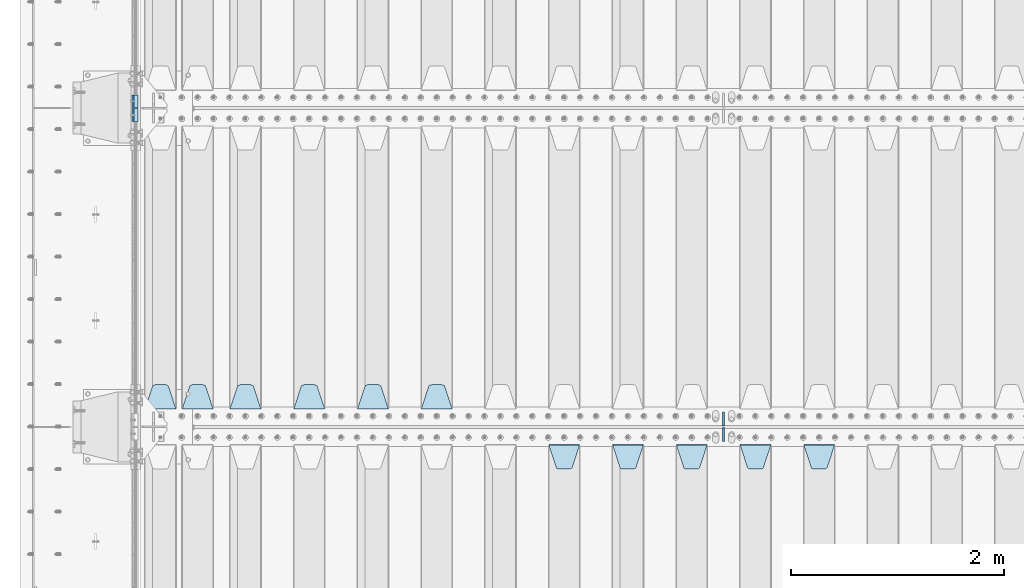
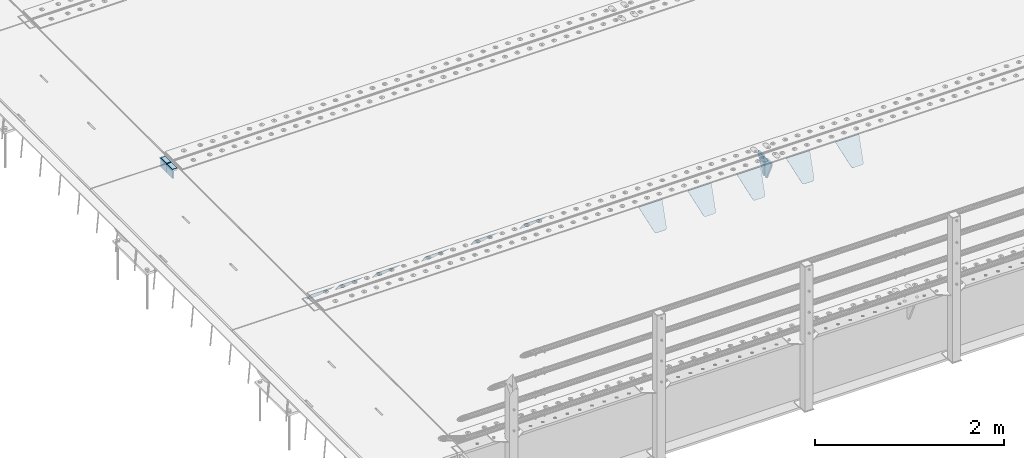
# One storey, part 205 of 257: 17 plates.
"""IFC2X3 building model written with IfcOpenShell, lengths in millimetres."""

from ifc_helpers import new_model, si_unit, frame, origin_with_axes, place, context, subcontext, project, spatial, faceted_brep, material, type_object, element, save


model = new_model("IFC2X3")

# Units and contexts
model_context = context("Model", 3, precision=1e-05, world=origin_with_axes())
body_context = subcontext(model_context, "Body", "Model", "MODEL_VIEW")
ifc_project = project(units=[si_unit("LENGTHUNIT", "METRE", prefix="MILLI"), si_unit("AREAUNIT", "SQUARE_METRE"), si_unit("VOLUMEUNIT", "CUBIC_METRE"), si_unit("MASSUNIT", "GRAM", prefix="KILO"), si_unit("TIMEUNIT", "SECOND"), si_unit("PLANEANGLEUNIT", "RADIAN"), si_unit("SOLIDANGLEUNIT", "STERADIAN"), si_unit("THERMODYNAMICTEMPERATUREUNIT", "DEGREE_CELSIUS"), si_unit("LUMINOUSINTENSITYUNIT", "LUMEN")], contexts=[model_context])

# Site, building, storey
site_placement = place(None, origin_with_axes())
site = spatial("IfcSite", under=ifc_project, at=site_placement, CompositionType="ELEMENT")
building_placement = place(site_placement, origin_with_axes())
building = spatial("IfcBuilding", under=site, at=building_placement, Name="Standard", CompositionType="ELEMENT")
storey_placement = place(building_placement, origin_with_axes())
storey = spatial("IfcBuildingStorey", under=building, at=storey_placement, Name="Undefined", CompositionType="ELEMENT", Elevation=0.0)

# Plates
ifc_material_1 = material()
plate_type_1 = type_object("IfcPlateType", PredefinedType="NOTDEFINED")
for number, where, z_axis, x_axis in (
    (1, (42440.00000006, 5935.00000043354, -16.0004050744733), (-1.0, 0.0, 0.0), (0.0, -4.95099999998473e-06, 0.999999999987744)),
    (2, (42439.99999994, 6065.00000045221, -16.0145962164944), (-1.0, 0.0, 0.0), (0.0, -4.95099999998473e-06, 0.999999999987744)),
):
    element("IfcPlate", number, at=place(storey_placement, frame(where, z_axis=z_axis, x_axis=x_axis)), inside=storey, type_object=plate_type_1, material=ifc_material_1, context=body_context, shape_type="Brep", body=[
        faceted_brep([(0.0, -60.0, 0.0), (-0.000933120085687023, -60.0, 60.0), (-0.000933120085687023, 60.0, 59.9999999999927), (0.0, 60.0, -7.27595761418343e-12), (24.9991450303709, -60.0, 60.0), (24.9991450303709, 60.0, 59.9999999999927), (26.544215218168, -60.0, 59.7552873850873), (26.544215218168, 60.0, 59.75528738508), (27.9380461396139, -60.0, 59.0451032459096), (27.9380461396139, 60.0, 59.0451032459096), (29.0442025908961, -60.0, 57.9389639895744), (29.0442025908961, 60.0, 57.9389639895744), (29.7544083969366, -60.0, 56.5451441080368), (29.7544083969366, 60.0, 56.5451441080295), (29.9991450297669, -60.0, 55.0000777244568), (29.9991450297669, 60.0, 55.0000777244495), (29.999922274335, -60.0, 5.00007772445679), (29.999922274335, 60.0, 5.00007772444951), (29.7552240705896, -60.0, 3.45497416452417), (29.7552240705896, 60.0, 3.45497416452417), (29.0450346578116, -60.0, 2.06111146690819), (29.0450346578116, 60.0, 2.06111146690819), (27.9388736885072, -60.0, 0.954933302316931), (27.9388736885072, 60.0, 0.954933302316931), (26.5450220308766, -60.0, 0.244722222181736), (26.5450220308766, 60.0, 0.244722222181736), (24.9999222749392, -60.0, 0.0), (24.9999222749392, 60.0, -7.27595761418343e-12)], [[[0, 1, 2, 3]], [[1, 4, 5, 2]], [[4, 6, 7, 5]], [[6, 8, 9, 7]], [[8, 10, 11, 9]], [[10, 12, 13, 11]], [[12, 14, 15, 13]], [[14, 16, 17, 15]], [[16, 18, 19, 17]], [[18, 20, 21, 19]], [[20, 22, 23, 21]], [[22, 24, 25, 23]], [[24, 26, 27, 25]], [[26, 0, 3, 27]], [[5, 7, 9, 11, 13, 15, 17, 19, 21, 23, 25, 27, 3, 2]], [[26, 24, 22, 20, 18, 16, 14, 12, 10, 8, 6, 4, 1, 0]]]),
    ])
ifc_material_2 = material(Name="STEEL/S355N")
plate_type_2 = type_object("IfcPlateType", PredefinedType="NOTDEFINED")
for number, where, z_axis, x_axis in (
    (3, (42390.0, 5995.00044598306, -106.000730104157), (0.0, -0.999999999987744, -4.95099999993769e-06), (0.0, -4.95099999998473e-06, 0.999999999987744)),
    (4, (42390.0, 6125.00044600192, -106.014921246643), (0.0, -0.999999999987744, -4.95099999993769e-06), (0.0, -4.95099999998473e-06, 0.999999999987744)),
):
    element("IfcPlate", number, at=place(storey_placement, frame(where, z_axis=z_axis, x_axis=x_axis)), inside=storey, type_object=plate_type_2, material=ifc_material_2, context=body_context, shape_type="Brep", body=[
        faceted_brep([(0.0, -10.0, 0.0), (5.7072624315424e-07, -10.0, 120.0), (5.7072624315424e-07, 10.0, 120.0), (0.0, 10.0, 0.0), (90.0, -10.0, 120.0), (90.0, 10.0, 120.0), (90.0, -10.0, 1.09139364212751e-11), (90.0, 10.0, 1.09139364212751e-11)], [[[0, 1, 2, 3]], [[1, 4, 5, 2]], [[4, 6, 7, 5]], [[6, 0, 3, 7]], [[5, 7, 3, 2]], [[6, 4, 1, 0]]]),
    ])
plate_type_3 = type_object("IfcPlateType", PredefinedType="NOTDEFINED")
plate_1_placement = place(storey_placement, frame((48705.0, 2831.76776695594, -1.767766952965), z_axis=(0.0, -0.707106781186548, -0.707106781186547), x_axis=(1.0, 0.0, 0.0)))
element("IfcPlate", 5, at=plate_1_placement, inside=storey, type_object=plate_type_3, material=ifc_material_2, context=body_context, shape_type="Brep", body=[
    faceted_brep([(0.0, -2.5, 0.0), (69.345504679477, -2.50000000000091, 300.17173142483), (69.345504679477, 2.5, 300.171731424831), (0.0, 2.5, 0.0), (70.927406119954, -2.50000000000091, 304.8974424154), (70.927406119954, 2.5, 304.8974424154), (73.3818627772271, -2.50000000000091, 309.234538108527), (73.3818627772271, 2.49999999999909, 309.234538108527), (76.6187032999587, -2.5, 313.023683126103), (76.6187032999587, 2.5, 313.023683126103), (80.5190132705029, -2.5, 316.125672595372), (80.5190132705029, 2.5, 316.125672595371), (84.9395038596849, -2.5, 318.426546230476), (84.9395038596849, 2.5, 318.426546230477), (89.7177759439219, -2.5, 319.841774983275), (89.7177759439219, 2.5, 319.841774983275), (94.6782862926484, -2.5, 320.319366455079), (94.6782862926484, 2.5, 320.319366455079), (195.321713707352, -2.5, 320.319366455079), (195.321713707352, 2.5, 320.319366455079), (200.282224056078, -2.5, 319.841774983275), (200.282224056078, 2.49999999999909, 319.841774983275), (205.060496140315, -2.5, 318.426546230476), (205.060496140315, 2.49999999999909, 318.426546230475), (209.480986729497, -2.5, 316.125672595371), (209.480986729497, 2.5, 316.125672595371), (213.381296700041, -2.50000000000091, 313.023683126102), (213.381296700041, 2.5, 313.023683126103), (216.618137222766, -2.50000000000091, 309.234538108527), (216.618137222766, 2.5, 309.234538108527), (219.072593880039, -2.5, 304.897442415399), (219.072593880039, 2.5, 304.897442415399), (220.654495320523, -2.50000000000091, 300.17173142483), (220.654495320523, 2.5, 300.171731424831), (290.0, -2.50000000000091, 0.0), (290.0, 2.5, 9.09494701772928e-13)], [[[0, 1, 2, 3]], [[1, 4, 5, 2]], [[4, 6, 7, 5]], [[6, 8, 9, 7]], [[8, 10, 11, 9]], [[10, 12, 13, 11]], [[12, 14, 15, 13]], [[14, 16, 17, 15]], [[16, 18, 19, 17]], [[18, 20, 21, 19]], [[20, 22, 23, 21]], [[22, 24, 25, 23]], [[24, 26, 27, 25]], [[26, 28, 29, 27]], [[28, 30, 31, 29]], [[30, 32, 33, 31]], [[32, 34, 35, 33]], [[34, 0, 3, 35]], [[5, 7, 9, 11, 13, 15, 17, 19, 21, 23, 25, 27, 29, 31, 33, 35, 3, 2]], [[34, 32, 30, 28, 26, 24, 22, 20, 18, 16, 14, 12, 10, 8, 6, 4, 1, 0]]]),
])
plate_2_placement = place(storey_placement, frame((48105.0, 2831.76776695594, -1.767766952965), z_axis=(0.0, -0.707106781186548, -0.707106781186547), x_axis=(1.0, 0.0, 0.0)))
element("IfcPlate", 6, at=plate_2_placement, inside=storey, type_object=plate_type_3, material=ifc_material_2, context=body_context, shape_type="Brep", body=[
    faceted_brep([(0.0, -2.5, 0.0), (69.345504679477, -2.50000000000091, 300.17173142483), (69.345504679477, 2.5, 300.171731424831), (0.0, 2.5, 0.0), (70.927406119954, -2.50000000000091, 304.8974424154), (70.927406119954, 2.5, 304.8974424154), (73.3818627772271, -2.50000000000091, 309.234538108527), (73.3818627772271, 2.49999999999909, 309.234538108527), (76.6187032999587, -2.5, 313.023683126103), (76.6187032999587, 2.5, 313.023683126103), (80.5190132705029, -2.5, 316.125672595372), (80.5190132705029, 2.5, 316.125672595371), (84.9395038596849, -2.5, 318.426546230476), (84.9395038596849, 2.5, 318.426546230477), (89.7177759439219, -2.5, 319.841774983275), (89.7177759439219, 2.5, 319.841774983275), (94.6782862926484, -2.5, 320.319366455079), (94.6782862926484, 2.5, 320.319366455079), (195.321713707352, -2.5, 320.319366455079), (195.321713707352, 2.5, 320.319366455079), (200.282224056078, -2.5, 319.841774983275), (200.282224056078, 2.49999999999909, 319.841774983275), (205.060496140315, -2.5, 318.426546230476), (205.060496140315, 2.49999999999909, 318.426546230475), (209.480986729497, -2.5, 316.125672595371), (209.480986729497, 2.5, 316.125672595371), (213.381296700041, -2.50000000000091, 313.023683126102), (213.381296700041, 2.5, 313.023683126103), (216.618137222766, -2.50000000000091, 309.234538108527), (216.618137222766, 2.5, 309.234538108527), (219.072593880039, -2.5, 304.897442415399), (219.072593880039, 2.5, 304.897442415399), (220.654495320523, -2.50000000000091, 300.17173142483), (220.654495320523, 2.5, 300.171731424831), (290.0, -2.50000000000091, 0.0), (290.0, 2.5, 9.09494701772928e-13)], [[[0, 1, 2, 3]], [[1, 4, 5, 2]], [[4, 6, 7, 5]], [[6, 8, 9, 7]], [[8, 10, 11, 9]], [[10, 12, 13, 11]], [[12, 14, 15, 13]], [[14, 16, 17, 15]], [[16, 18, 19, 17]], [[18, 20, 21, 19]], [[20, 22, 23, 21]], [[22, 24, 25, 23]], [[24, 26, 27, 25]], [[26, 28, 29, 27]], [[28, 30, 31, 29]], [[30, 32, 33, 31]], [[32, 34, 35, 33]], [[34, 0, 3, 35]], [[5, 7, 9, 11, 13, 15, 17, 19, 21, 23, 25, 27, 29, 31, 33, 35, 3, 2]], [[34, 32, 30, 28, 26, 24, 22, 20, 18, 16, 14, 12, 10, 8, 6, 4, 1, 0]]]),
])
plate_3_placement = place(storey_placement, frame((47505.0, 2831.76776695594, -1.767766952965), z_axis=(0.0, -0.707106781186548, -0.707106781186547), x_axis=(1.0, 0.0, 0.0)))
element("IfcPlate", 7, at=plate_3_placement, inside=storey, type_object=plate_type_3, material=ifc_material_2, context=body_context, shape_type="Brep", body=[
    faceted_brep([(0.0, -2.5, 0.0), (69.345504679477, -2.50000000000091, 300.17173142483), (69.345504679477, 2.5, 300.171731424831), (0.0, 2.5, 0.0), (70.927406119954, -2.50000000000091, 304.8974424154), (70.927406119954, 2.5, 304.8974424154), (73.3818627772271, -2.50000000000091, 309.234538108527), (73.3818627772271, 2.49999999999909, 309.234538108527), (76.6187032999587, -2.5, 313.023683126103), (76.6187032999587, 2.5, 313.023683126103), (80.5190132705029, -2.5, 316.125672595372), (80.5190132705029, 2.5, 316.125672595371), (84.9395038596849, -2.5, 318.426546230476), (84.9395038596849, 2.5, 318.426546230477), (89.7177759439219, -2.5, 319.841774983275), (89.7177759439219, 2.5, 319.841774983275), (94.6782862926484, -2.5, 320.319366455079), (94.6782862926484, 2.5, 320.319366455079), (195.321713707352, -2.5, 320.319366455079), (195.321713707352, 2.5, 320.319366455079), (200.282224056078, -2.5, 319.841774983275), (200.282224056078, 2.49999999999909, 319.841774983275), (205.060496140315, -2.5, 318.426546230476), (205.060496140315, 2.49999999999909, 318.426546230475), (209.480986729497, -2.5, 316.125672595371), (209.480986729497, 2.5, 316.125672595371), (213.381296700041, -2.50000000000091, 313.023683126102), (213.381296700041, 2.5, 313.023683126103), (216.618137222766, -2.50000000000091, 309.234538108527), (216.618137222766, 2.5, 309.234538108527), (219.072593880039, -2.5, 304.897442415399), (219.072593880039, 2.5, 304.897442415399), (220.654495320523, -2.50000000000091, 300.17173142483), (220.654495320523, 2.5, 300.171731424831), (290.0, -2.50000000000091, 0.0), (290.0, 2.5, 9.09494701772928e-13)], [[[0, 1, 2, 3]], [[1, 4, 5, 2]], [[4, 6, 7, 5]], [[6, 8, 9, 7]], [[8, 10, 11, 9]], [[10, 12, 13, 11]], [[12, 14, 15, 13]], [[14, 16, 17, 15]], [[16, 18, 19, 17]], [[18, 20, 21, 19]], [[20, 22, 23, 21]], [[22, 24, 25, 23]], [[24, 26, 27, 25]], [[26, 28, 29, 27]], [[28, 30, 31, 29]], [[30, 32, 33, 31]], [[32, 34, 35, 33]], [[34, 0, 3, 35]], [[5, 7, 9, 11, 13, 15, 17, 19, 21, 23, 25, 27, 29, 31, 33, 35, 3, 2]], [[34, 32, 30, 28, 26, 24, 22, 20, 18, 16, 14, 12, 10, 8, 6, 4, 1, 0]]]),
])
plate_4_placement = place(storey_placement, frame((46905.0, 2831.76776695594, -1.767766952965), z_axis=(0.0, -0.707106781186548, -0.707106781186547), x_axis=(1.0, 0.0, 0.0)))
element("IfcPlate", 8, at=plate_4_placement, inside=storey, type_object=plate_type_3, material=ifc_material_2, context=body_context, shape_type="Brep", body=[
    faceted_brep([(0.0, -2.5, 0.0), (69.345504679477, -2.50000000000091, 300.17173142483), (69.345504679477, 2.5, 300.171731424831), (0.0, 2.5, 0.0), (70.927406119954, -2.50000000000091, 304.8974424154), (70.927406119954, 2.5, 304.8974424154), (73.3818627772271, -2.50000000000091, 309.234538108527), (73.3818627772271, 2.49999999999909, 309.234538108527), (76.6187032999587, -2.5, 313.023683126103), (76.6187032999587, 2.5, 313.023683126103), (80.5190132705029, -2.5, 316.125672595372), (80.5190132705029, 2.5, 316.125672595371), (84.9395038596849, -2.5, 318.426546230476), (84.9395038596849, 2.5, 318.426546230477), (89.7177759439219, -2.5, 319.841774983275), (89.7177759439219, 2.5, 319.841774983275), (94.6782862926484, -2.5, 320.319366455079), (94.6782862926484, 2.5, 320.319366455079), (195.321713707352, -2.5, 320.319366455079), (195.321713707352, 2.5, 320.319366455079), (200.282224056078, -2.5, 319.841774983275), (200.282224056078, 2.49999999999909, 319.841774983275), (205.060496140315, -2.5, 318.426546230476), (205.060496140315, 2.49999999999909, 318.426546230475), (209.480986729497, -2.5, 316.125672595371), (209.480986729497, 2.5, 316.125672595371), (213.381296700041, -2.50000000000091, 313.023683126102), (213.381296700041, 2.5, 313.023683126103), (216.618137222766, -2.50000000000091, 309.234538108527), (216.618137222766, 2.5, 309.234538108527), (219.072593880039, -2.5, 304.897442415399), (219.072593880039, 2.5, 304.897442415399), (220.654495320523, -2.50000000000091, 300.17173142483), (220.654495320523, 2.5, 300.171731424831), (290.0, -2.50000000000091, 0.0), (290.0, 2.5, 9.09494701772928e-13)], [[[0, 1, 2, 3]], [[1, 4, 5, 2]], [[4, 6, 7, 5]], [[6, 8, 9, 7]], [[8, 10, 11, 9]], [[10, 12, 13, 11]], [[12, 14, 15, 13]], [[14, 16, 17, 15]], [[16, 18, 19, 17]], [[18, 20, 21, 19]], [[20, 22, 23, 21]], [[22, 24, 25, 23]], [[24, 26, 27, 25]], [[26, 28, 29, 27]], [[28, 30, 31, 29]], [[30, 32, 33, 31]], [[32, 34, 35, 33]], [[34, 0, 3, 35]], [[5, 7, 9, 11, 13, 15, 17, 19, 21, 23, 25, 27, 29, 31, 33, 35, 3, 2]], [[34, 32, 30, 28, 26, 24, 22, 20, 18, 16, 14, 12, 10, 8, 6, 4, 1, 0]]]),
])
plate_5_placement = place(storey_placement, frame((46305.0, 2831.76776695594, -1.767766952965), z_axis=(0.0, -0.707106781186548, -0.707106781186547), x_axis=(1.0, 0.0, 0.0)))
element("IfcPlate", 9, at=plate_5_placement, inside=storey, type_object=plate_type_3, material=ifc_material_2, context=body_context, shape_type="Brep", body=[
    faceted_brep([(0.0, -2.5, 0.0), (69.345504679477, -2.50000000000091, 300.17173142483), (69.345504679477, 2.5, 300.171731424831), (0.0, 2.5, 0.0), (70.927406119954, -2.50000000000091, 304.8974424154), (70.927406119954, 2.5, 304.8974424154), (73.3818627772271, -2.50000000000091, 309.234538108527), (73.3818627772271, 2.49999999999909, 309.234538108527), (76.6187032999587, -2.5, 313.023683126103), (76.6187032999587, 2.5, 313.023683126103), (80.5190132705029, -2.5, 316.125672595372), (80.5190132705029, 2.5, 316.125672595371), (84.9395038596849, -2.5, 318.426546230476), (84.9395038596849, 2.5, 318.426546230477), (89.7177759439219, -2.5, 319.841774983275), (89.7177759439219, 2.5, 319.841774983275), (94.6782862926484, -2.5, 320.319366455079), (94.6782862926484, 2.5, 320.319366455079), (195.321713707352, -2.5, 320.319366455079), (195.321713707352, 2.5, 320.319366455079), (200.282224056078, -2.5, 319.841774983275), (200.282224056078, 2.49999999999909, 319.841774983275), (205.060496140315, -2.5, 318.426546230476), (205.060496140315, 2.49999999999909, 318.426546230475), (209.480986729497, -2.5, 316.125672595371), (209.480986729497, 2.5, 316.125672595371), (213.381296700041, -2.50000000000091, 313.023683126102), (213.381296700041, 2.5, 313.023683126103), (216.618137222766, -2.50000000000091, 309.234538108527), (216.618137222766, 2.5, 309.234538108527), (219.072593880039, -2.5, 304.897442415399), (219.072593880039, 2.5, 304.897442415399), (220.654495320523, -2.50000000000091, 300.17173142483), (220.654495320523, 2.5, 300.171731424831), (290.0, -2.50000000000091, 0.0), (290.0, 2.5, 9.09494701772928e-13)], [[[0, 1, 2, 3]], [[1, 4, 5, 2]], [[4, 6, 7, 5]], [[6, 8, 9, 7]], [[8, 10, 11, 9]], [[10, 12, 13, 11]], [[12, 14, 15, 13]], [[14, 16, 17, 15]], [[16, 18, 19, 17]], [[18, 20, 21, 19]], [[20, 22, 23, 21]], [[22, 24, 25, 23]], [[24, 26, 27, 25]], [[26, 28, 29, 27]], [[28, 30, 31, 29]], [[30, 32, 33, 31]], [[32, 34, 35, 33]], [[34, 0, 3, 35]], [[5, 7, 9, 11, 13, 15, 17, 19, 21, 23, 25, 27, 29, 31, 33, 35, 3, 2]], [[34, 32, 30, 28, 26, 24, 22, 20, 18, 16, 14, 12, 10, 8, 6, 4, 1, 0]]]),
])
plate_6_placement = place(storey_placement, frame((45395.0, 3168.23223304703, -1.76776695296758), z_axis=(0.0, 0.707106781186547, -0.707106781186548), x_axis=(-1.0, 0.0, 0.0)))
element("IfcPlate", 10, at=plate_6_placement, inside=storey, type_object=plate_type_3, material=ifc_material_2, context=body_context, shape_type="Brep", body=[
    faceted_brep([(0.0, -2.5, 0.0), (69.345504679477, -2.50000000000091, 300.17173142483), (69.345504679477, 2.5, 300.171731424831), (0.0, 2.5, 0.0), (70.927406119954, -2.50000000000091, 304.8974424154), (70.927406119954, 2.5, 304.8974424154), (73.3818627772271, -2.50000000000091, 309.234538108527), (73.3818627772271, 2.49999999999909, 309.234538108527), (76.6187032999587, -2.5, 313.023683126103), (76.6187032999587, 2.5, 313.023683126103), (80.5190132705029, -2.5, 316.125672595372), (80.5190132705029, 2.5, 316.125672595371), (84.9395038596849, -2.5, 318.426546230476), (84.9395038596849, 2.5, 318.426546230477), (89.7177759439219, -2.5, 319.841774983275), (89.7177759439219, 2.5, 319.841774983275), (94.6782862926484, -2.5, 320.319366455079), (94.6782862926484, 2.5, 320.319366455079), (195.321713707352, -2.5, 320.319366455079), (195.321713707352, 2.5, 320.319366455079), (200.282224056078, -2.5, 319.841774983275), (200.282224056078, 2.49999999999909, 319.841774983275), (205.060496140315, -2.5, 318.426546230476), (205.060496140315, 2.49999999999909, 318.426546230475), (209.480986729497, -2.5, 316.125672595371), (209.480986729497, 2.5, 316.125672595371), (213.381296700041, -2.50000000000091, 313.023683126102), (213.381296700041, 2.5, 313.023683126103), (216.618137222766, -2.50000000000091, 309.234538108527), (216.618137222766, 2.5, 309.234538108527), (219.072593880039, -2.5, 304.897442415399), (219.072593880039, 2.5, 304.897442415399), (220.654495320523, -2.50000000000091, 300.17173142483), (220.654495320523, 2.5, 300.171731424831), (290.0, -2.50000000000091, 0.0), (290.0, 2.5, 9.09494701772928e-13)], [[[0, 1, 2, 3]], [[1, 4, 5, 2]], [[4, 6, 7, 5]], [[6, 8, 9, 7]], [[8, 10, 11, 9]], [[10, 12, 13, 11]], [[12, 14, 15, 13]], [[14, 16, 17, 15]], [[16, 18, 19, 17]], [[18, 20, 21, 19]], [[20, 22, 23, 21]], [[22, 24, 25, 23]], [[24, 26, 27, 25]], [[26, 28, 29, 27]], [[28, 30, 31, 29]], [[30, 32, 33, 31]], [[32, 34, 35, 33]], [[34, 0, 3, 35]], [[5, 7, 9, 11, 13, 15, 17, 19, 21, 23, 25, 27, 29, 31, 33, 35, 3, 2]], [[34, 32, 30, 28, 26, 24, 22, 20, 18, 16, 14, 12, 10, 8, 6, 4, 1, 0]]]),
])
plate_7_placement = place(storey_placement, frame((44795.0, 3168.23223304703, -1.76776695296758), z_axis=(0.0, 0.707106781186547, -0.707106781186548), x_axis=(-1.0, 0.0, 0.0)))
element("IfcPlate", 11, at=plate_7_placement, inside=storey, type_object=plate_type_3, material=ifc_material_2, context=body_context, shape_type="Brep", body=[
    faceted_brep([(0.0, -2.5, 0.0), (69.345504679477, -2.50000000000091, 300.17173142483), (69.345504679477, 2.5, 300.171731424831), (0.0, 2.5, 0.0), (70.927406119954, -2.50000000000091, 304.8974424154), (70.927406119954, 2.5, 304.8974424154), (73.3818627772271, -2.50000000000091, 309.234538108527), (73.3818627772271, 2.49999999999909, 309.234538108527), (76.6187032999587, -2.5, 313.023683126103), (76.6187032999587, 2.5, 313.023683126103), (80.5190132705029, -2.5, 316.125672595372), (80.5190132705029, 2.5, 316.125672595371), (84.9395038596849, -2.5, 318.426546230476), (84.9395038596849, 2.5, 318.426546230477), (89.7177759439219, -2.5, 319.841774983275), (89.7177759439219, 2.5, 319.841774983275), (94.6782862926484, -2.5, 320.319366455079), (94.6782862926484, 2.5, 320.319366455079), (195.321713707352, -2.5, 320.319366455079), (195.321713707352, 2.5, 320.319366455079), (200.282224056078, -2.5, 319.841774983275), (200.282224056078, 2.49999999999909, 319.841774983275), (205.060496140315, -2.5, 318.426546230476), (205.060496140315, 2.49999999999909, 318.426546230475), (209.480986729497, -2.5, 316.125672595371), (209.480986729497, 2.5, 316.125672595371), (213.381296700041, -2.50000000000091, 313.023683126102), (213.381296700041, 2.5, 313.023683126103), (216.618137222766, -2.50000000000091, 309.234538108527), (216.618137222766, 2.5, 309.234538108527), (219.072593880039, -2.5, 304.897442415399), (219.072593880039, 2.5, 304.897442415399), (220.654495320523, -2.50000000000091, 300.17173142483), (220.654495320523, 2.5, 300.171731424831), (290.0, -2.50000000000091, 0.0), (290.0, 2.5, 9.09494701772928e-13)], [[[0, 1, 2, 3]], [[1, 4, 5, 2]], [[4, 6, 7, 5]], [[6, 8, 9, 7]], [[8, 10, 11, 9]], [[10, 12, 13, 11]], [[12, 14, 15, 13]], [[14, 16, 17, 15]], [[16, 18, 19, 17]], [[18, 20, 21, 19]], [[20, 22, 23, 21]], [[22, 24, 25, 23]], [[24, 26, 27, 25]], [[26, 28, 29, 27]], [[28, 30, 31, 29]], [[30, 32, 33, 31]], [[32, 34, 35, 33]], [[34, 0, 3, 35]], [[5, 7, 9, 11, 13, 15, 17, 19, 21, 23, 25, 27, 29, 31, 33, 35, 3, 2]], [[34, 32, 30, 28, 26, 24, 22, 20, 18, 16, 14, 12, 10, 8, 6, 4, 1, 0]]]),
])
plate_8_placement = place(storey_placement, frame((44195.0, 3168.23223304703, -1.76776695296758), z_axis=(0.0, 0.707106781186547, -0.707106781186548), x_axis=(-1.0, 0.0, 0.0)))
element("IfcPlate", 12, at=plate_8_placement, inside=storey, type_object=plate_type_3, material=ifc_material_2, context=body_context, shape_type="Brep", body=[
    faceted_brep([(0.0, -2.5, 0.0), (69.345504679477, -2.50000000000091, 300.17173142483), (69.345504679477, 2.5, 300.171731424831), (0.0, 2.5, 0.0), (70.927406119954, -2.50000000000091, 304.8974424154), (70.927406119954, 2.5, 304.8974424154), (73.3818627772271, -2.50000000000091, 309.234538108527), (73.3818627772271, 2.49999999999909, 309.234538108527), (76.6187032999587, -2.5, 313.023683126103), (76.6187032999587, 2.5, 313.023683126103), (80.5190132705029, -2.5, 316.125672595372), (80.5190132705029, 2.5, 316.125672595371), (84.9395038596849, -2.5, 318.426546230476), (84.9395038596849, 2.5, 318.426546230477), (89.7177759439219, -2.5, 319.841774983275), (89.7177759439219, 2.5, 319.841774983275), (94.6782862926484, -2.5, 320.319366455079), (94.6782862926484, 2.5, 320.319366455079), (195.321713707352, -2.5, 320.319366455079), (195.321713707352, 2.5, 320.319366455079), (200.282224056078, -2.5, 319.841774983275), (200.282224056078, 2.49999999999909, 319.841774983275), (205.060496140315, -2.5, 318.426546230476), (205.060496140315, 2.49999999999909, 318.426546230475), (209.480986729497, -2.5, 316.125672595371), (209.480986729497, 2.5, 316.125672595371), (213.381296700041, -2.50000000000091, 313.023683126102), (213.381296700041, 2.5, 313.023683126103), (216.618137222766, -2.50000000000091, 309.234538108527), (216.618137222766, 2.5, 309.234538108527), (219.072593880039, -2.5, 304.897442415399), (219.072593880039, 2.5, 304.897442415399), (220.654495320523, -2.50000000000091, 300.17173142483), (220.654495320523, 2.5, 300.171731424831), (290.0, -2.50000000000091, 0.0), (290.0, 2.5, 9.09494701772928e-13)], [[[0, 1, 2, 3]], [[1, 4, 5, 2]], [[4, 6, 7, 5]], [[6, 8, 9, 7]], [[8, 10, 11, 9]], [[10, 12, 13, 11]], [[12, 14, 15, 13]], [[14, 16, 17, 15]], [[16, 18, 19, 17]], [[18, 20, 21, 19]], [[20, 22, 23, 21]], [[22, 24, 25, 23]], [[24, 26, 27, 25]], [[26, 28, 29, 27]], [[28, 30, 31, 29]], [[30, 32, 33, 31]], [[32, 34, 35, 33]], [[34, 0, 3, 35]], [[5, 7, 9, 11, 13, 15, 17, 19, 21, 23, 25, 27, 29, 31, 33, 35, 3, 2]], [[34, 32, 30, 28, 26, 24, 22, 20, 18, 16, 14, 12, 10, 8, 6, 4, 1, 0]]]),
])
plate_9_placement = place(storey_placement, frame((43595.0, 3168.23223304703, -1.76776695296758), z_axis=(0.0, 0.707106781186547, -0.707106781186548), x_axis=(-1.0, 0.0, 0.0)))
element("IfcPlate", 13, at=plate_9_placement, inside=storey, type_object=plate_type_3, material=ifc_material_2, context=body_context, shape_type="Brep", body=[
    faceted_brep([(0.0, -2.5, 0.0), (69.345504679477, -2.50000000000091, 300.17173142483), (69.345504679477, 2.5, 300.171731424831), (0.0, 2.5, 0.0), (70.927406119954, -2.50000000000091, 304.8974424154), (70.927406119954, 2.5, 304.8974424154), (73.3818627772271, -2.50000000000091, 309.234538108527), (73.3818627772271, 2.49999999999909, 309.234538108527), (76.6187032999587, -2.5, 313.023683126103), (76.6187032999587, 2.5, 313.023683126103), (80.5190132705029, -2.5, 316.125672595372), (80.5190132705029, 2.5, 316.125672595371), (84.9395038596849, -2.5, 318.426546230476), (84.9395038596849, 2.5, 318.426546230477), (89.7177759439219, -2.5, 319.841774983275), (89.7177759439219, 2.5, 319.841774983275), (94.6782862926484, -2.5, 320.319366455079), (94.6782862926484, 2.5, 320.319366455079), (195.321713707352, -2.5, 320.319366455079), (195.321713707352, 2.5, 320.319366455079), (200.282224056078, -2.5, 319.841774983275), (200.282224056078, 2.49999999999909, 319.841774983275), (205.060496140315, -2.5, 318.426546230476), (205.060496140315, 2.49999999999909, 318.426546230475), (209.480986729497, -2.5, 316.125672595371), (209.480986729497, 2.5, 316.125672595371), (213.381296700041, -2.50000000000091, 313.023683126102), (213.381296700041, 2.5, 313.023683126103), (216.618137222766, -2.50000000000091, 309.234538108527), (216.618137222766, 2.5, 309.234538108527), (219.072593880039, -2.5, 304.897442415399), (219.072593880039, 2.5, 304.897442415399), (220.654495320523, -2.50000000000091, 300.17173142483), (220.654495320523, 2.5, 300.171731424831), (290.0, -2.50000000000091, 0.0), (290.0, 2.5, 9.09494701772928e-13)], [[[0, 1, 2, 3]], [[1, 4, 5, 2]], [[4, 6, 7, 5]], [[6, 8, 9, 7]], [[8, 10, 11, 9]], [[10, 12, 13, 11]], [[12, 14, 15, 13]], [[14, 16, 17, 15]], [[16, 18, 19, 17]], [[18, 20, 21, 19]], [[20, 22, 23, 21]], [[22, 24, 25, 23]], [[24, 26, 27, 25]], [[26, 28, 29, 27]], [[28, 30, 31, 29]], [[30, 32, 33, 31]], [[32, 34, 35, 33]], [[34, 0, 3, 35]], [[5, 7, 9, 11, 13, 15, 17, 19, 21, 23, 25, 27, 29, 31, 33, 35, 3, 2]], [[34, 32, 30, 28, 26, 24, 22, 20, 18, 16, 14, 12, 10, 8, 6, 4, 1, 0]]]),
])
plate_10_placement = place(storey_placement, frame((43145.0, 3168.23223304703, -1.76776695296758), z_axis=(0.0, 0.707106781186547, -0.707106781186548), x_axis=(-1.0, 0.0, 0.0)))
element("IfcPlate", 14, at=plate_10_placement, inside=storey, type_object=plate_type_3, material=ifc_material_2, context=body_context, shape_type="Brep", body=[
    faceted_brep([(0.0, -2.5, 0.0), (69.345504679477, -2.50000000000091, 300.17173142483), (69.345504679477, 2.5, 300.171731424831), (0.0, 2.5, 0.0), (70.927406119954, -2.50000000000091, 304.8974424154), (70.927406119954, 2.5, 304.8974424154), (73.3818627772271, -2.50000000000091, 309.234538108527), (73.3818627772271, 2.49999999999909, 309.234538108527), (76.6187032999587, -2.5, 313.023683126103), (76.6187032999587, 2.5, 313.023683126103), (80.5190132705029, -2.5, 316.125672595372), (80.5190132705029, 2.5, 316.125672595371), (84.9395038596849, -2.5, 318.426546230476), (84.9395038596849, 2.5, 318.426546230477), (89.7177759439219, -2.5, 319.841774983275), (89.7177759439219, 2.5, 319.841774983275), (94.6782862926484, -2.5, 320.319366455079), (94.6782862926484, 2.5, 320.319366455079), (195.321713707352, -2.5, 320.319366455079), (195.321713707352, 2.5, 320.319366455079), (200.282224056078, -2.5, 319.841774983275), (200.282224056078, 2.49999999999909, 319.841774983275), (205.060496140315, -2.5, 318.426546230476), (205.060496140315, 2.49999999999909, 318.426546230475), (209.480986729497, -2.5, 316.125672595371), (209.480986729497, 2.5, 316.125672595371), (213.381296700041, -2.50000000000091, 313.023683126102), (213.381296700041, 2.5, 313.023683126103), (216.618137222766, -2.50000000000091, 309.234538108527), (216.618137222766, 2.5, 309.234538108527), (219.072593880039, -2.5, 304.897442415399), (219.072593880039, 2.5, 304.897442415399), (220.654495320523, -2.50000000000091, 300.17173142483), (220.654495320523, 2.5, 300.171731424831), (290.0, -2.50000000000091, 0.0), (290.0, 2.5, 9.09494701772928e-13)], [[[0, 1, 2, 3]], [[1, 4, 5, 2]], [[4, 6, 7, 5]], [[6, 8, 9, 7]], [[8, 10, 11, 9]], [[10, 12, 13, 11]], [[12, 14, 15, 13]], [[14, 16, 17, 15]], [[16, 18, 19, 17]], [[18, 20, 21, 19]], [[20, 22, 23, 21]], [[22, 24, 25, 23]], [[24, 26, 27, 25]], [[26, 28, 29, 27]], [[28, 30, 31, 29]], [[30, 32, 33, 31]], [[32, 34, 35, 33]], [[34, 0, 3, 35]], [[5, 7, 9, 11, 13, 15, 17, 19, 21, 23, 25, 27, 29, 31, 33, 35, 3, 2]], [[34, 32, 30, 28, 26, 24, 22, 20, 18, 16, 14, 12, 10, 8, 6, 4, 1, 0]]]),
])
plate_11_placement = place(storey_placement, frame((42795.0, 3168.23223304703, -1.76776695296758), z_axis=(0.0, 0.707106781186547, -0.707106781186548), x_axis=(-1.0, 0.0, 0.0)))
element("IfcPlate", 15, at=plate_11_placement, inside=storey, type_object=plate_type_3, material=ifc_material_2, context=body_context, shape_type="Brep", body=[
    faceted_brep([(0.0, -2.5, 0.0), (69.345504679477, -2.50000000000091, 300.17173142483), (69.345504679477, 2.5, 300.171731424831), (0.0, 2.5, 0.0), (70.927406119954, -2.50000000000091, 304.8974424154), (70.927406119954, 2.5, 304.8974424154), (73.3818627772271, -2.50000000000091, 309.234538108527), (73.3818627772271, 2.49999999999909, 309.234538108527), (76.6187032999587, -2.5, 313.023683126103), (76.6187032999587, 2.5, 313.023683126103), (80.5190132705029, -2.5, 316.125672595372), (80.5190132705029, 2.5, 316.125672595371), (84.9395038596849, -2.5, 318.426546230476), (84.9395038596849, 2.5, 318.426546230477), (89.7177759439219, -2.5, 319.841774983275), (89.7177759439219, 2.5, 319.841774983275), (94.6782862926484, -2.5, 320.319366455079), (94.6782862926484, 2.5, 320.319366455079), (195.321713707352, -2.5, 320.319366455079), (195.321713707352, 2.5, 320.319366455079), (200.282224056078, -2.5, 319.841774983275), (200.282224056078, 2.49999999999909, 319.841774983275), (205.060496140315, -2.5, 318.426546230476), (205.060496140315, 2.49999999999909, 318.426546230475), (209.480986729497, -2.5, 316.125672595371), (209.480986729497, 2.5, 316.125672595371), (213.381296700041, -2.50000000000091, 313.023683126102), (213.381296700041, 2.5, 313.023683126103), (216.618137222766, -2.50000000000091, 309.234538108527), (216.618137222766, 2.5, 309.234538108527), (219.072593880039, -2.5, 304.897442415399), (219.072593880039, 2.5, 304.897442415399), (220.654495320523, -2.50000000000091, 300.17173142483), (220.654495320523, 2.5, 300.171731424831), (290.0, -2.50000000000091, 0.0), (290.0, 2.5, 9.09494701772928e-13)], [[[0, 1, 2, 3]], [[1, 4, 5, 2]], [[4, 6, 7, 5]], [[6, 8, 9, 7]], [[8, 10, 11, 9]], [[10, 12, 13, 11]], [[12, 14, 15, 13]], [[14, 16, 17, 15]], [[16, 18, 19, 17]], [[18, 20, 21, 19]], [[20, 22, 23, 21]], [[22, 24, 25, 23]], [[24, 26, 27, 25]], [[26, 28, 29, 27]], [[28, 30, 31, 29]], [[30, 32, 33, 31]], [[32, 34, 35, 33]], [[34, 0, 3, 35]], [[5, 7, 9, 11, 13, 15, 17, 19, 21, 23, 25, 27, 29, 31, 33, 35, 3, 2]], [[34, 32, 30, 28, 26, 24, 22, 20, 18, 16, 14, 12, 10, 8, 6, 4, 1, 0]]]),
])
plate_type_4 = type_object("IfcPlateType", PredefinedType="NOTDEFINED")
for number, where, z_axis, x_axis in (
    (16, (47950.0, 3140.0, -30.0), (0.0, 0.0, -1.0), (0.0, -1.0, 0.0)),
    (17, (47950.0, 2860.0, -30.0), (0.0, 0.0, -1.0), (0.0, 1.0, 0.0)),
):
    element("IfcPlate", number, at=place(storey_placement, frame(where, z_axis=z_axis, x_axis=x_axis)), inside=storey, type_object=plate_type_4, material=ifc_material_2, context=body_context, shape_type="Brep", body=[
        faceted_brep([(0.0, -10.0, 0.0), (0.0, -10.0, 30.0), (0.0, 10.0, 30.0), (0.0, 10.0, 0.0), (102.0, -10.0, 250.0), (102.0, 10.0, 250.0), (132.0, -10.0, 250.0), (132.0, 10.0, 250.0), (132.0, -10.0, 30.0), (132.0, 10.0, 30.0), (131.544232590366, -10.0, 24.790554669992), (131.544232590366, 10.0, 24.790554669992), (130.190778623577, -10.0, 19.7393957002299), (130.190778623577, 10.0, 19.7393957002299), (127.980762113533, -10.0, 15.0), (127.980762113533, 10.0, 15.0), (124.981333293569, -10.0, 10.7163717094038), (124.981333293569, 10.0, 10.7163717094038), (121.283628290596, -10.0, 7.01866670643062), (121.283628290596, 10.0, 7.01866670643062), (117.0, -10.0, 4.01923788646684), (117.0, 10.0, 4.01923788646684), (112.26060429977, -10.0, 1.80922137642278), (112.26060429977, 10.0, 1.80922137642278), (107.209445330008, -10.0, 0.455767409633722), (107.209445330008, 10.0, 0.455767409633722), (102.0, -10.0, 0.0), (102.0, 10.0, 0.0)], [[[0, 1, 2, 3]], [[1, 4, 5, 2]], [[4, 6, 7, 5]], [[6, 8, 9, 7]], [[8, 10, 11, 9]], [[10, 12, 13, 11]], [[12, 14, 15, 13]], [[14, 16, 17, 15]], [[16, 18, 19, 17]], [[18, 20, 21, 19]], [[20, 22, 23, 21]], [[22, 24, 25, 23]], [[24, 26, 27, 25]], [[26, 0, 3, 27]], [[5, 7, 9, 11, 13, 15, 17, 19, 21, 23, 25, 27, 3, 2]], [[26, 24, 22, 20, 18, 16, 14, 12, 10, 8, 6, 4, 1, 0]]]),
    ])

save(model, "model.ifc")
